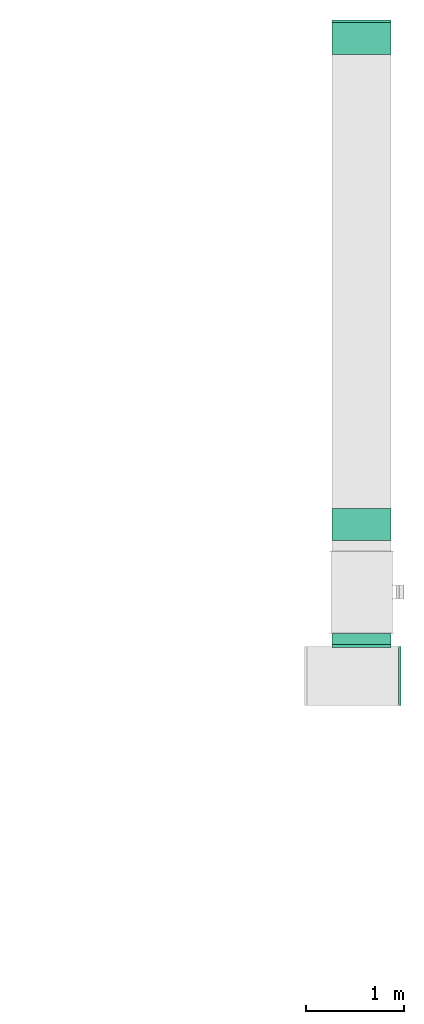
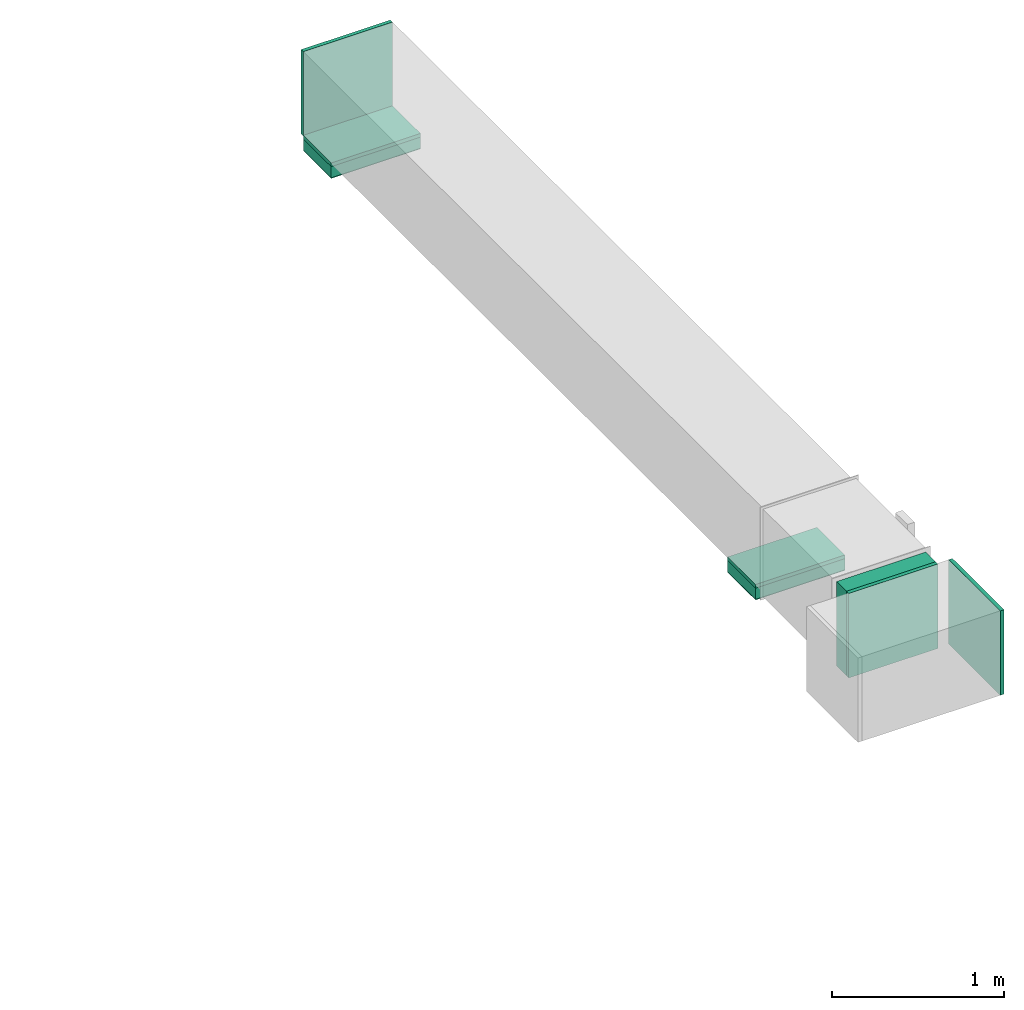
# One storey, part 5 of 9: 5 flow fittings, 3 flow segments, 2 flow terminals.
"""IFC2X3 building model written with IfcOpenShell, lengths in millimetres."""

from ifc_helpers import new_model, entity, si_unit, converted_unit, derived_unit, direction, frame, frame_2d, origin, origin_2d_with_axis, place, context, subcontext, project, spatial, rectangle, extrude, source, transform, mapped, material, type_object, type_shapes, element, save


model = new_model("IFC2X3")

# Units and contexts
model_context = context("Model", 3, precision=0.01, world=origin(), true_north=direction((6.12303176911189e-17, 1.0)))
body_context = subcontext(model_context, "Body", "Model", "MODEL_VIEW")
ifc_project = project(units=[si_unit("LENGTHUNIT", "METRE", prefix="MILLI"), si_unit("AREAUNIT", "SQUARE_METRE"), si_unit("VOLUMEUNIT", "CUBIC_METRE"), converted_unit("PLANEANGLEUNIT", "DEGREE", entity("IfcRatioMeasure", 0.0174532925199433), si_unit("PLANEANGLEUNIT", "RADIAN"), dimensions=[0, 0, 0, 0, 0, 0, 0]), si_unit("MASSUNIT", "GRAM", prefix="KILO"), derived_unit("MASSDENSITYUNIT", [(si_unit("MASSUNIT", "GRAM", prefix="KILO"), 1), (si_unit("LENGTHUNIT", "METRE"), -3)]), derived_unit("MOMENTOFINERTIAUNIT", [(si_unit("LENGTHUNIT", "METRE"), 4)]), si_unit("TIMEUNIT", "SECOND"), si_unit("FREQUENCYUNIT", "HERTZ"), si_unit("THERMODYNAMICTEMPERATUREUNIT", "DEGREE_CELSIUS"), derived_unit("THERMALTRANSMITTANCEUNIT", [(si_unit("MASSUNIT", "GRAM", prefix="KILO"), 1), (si_unit("THERMODYNAMICTEMPERATUREUNIT", "KELVIN"), -1), (si_unit("TIMEUNIT", "SECOND"), -3)]), derived_unit("VOLUMETRICFLOWRATEUNIT", [(si_unit("LENGTHUNIT", "METRE"), 3), (si_unit("TIMEUNIT", "SECOND"), -1)]), derived_unit("MASSFLOWRATEUNIT", [(si_unit("MASSUNIT", "GRAM", prefix="KILO"), 1), (si_unit("TIMEUNIT", "SECOND"), -1)]), derived_unit("ROTATIONALFREQUENCYUNIT", [(si_unit("TIMEUNIT", "SECOND"), -1)]), si_unit("ELECTRICCURRENTUNIT", "AMPERE"), si_unit("ELECTRICVOLTAGEUNIT", "VOLT"), si_unit("POWERUNIT", "WATT"), si_unit("FORCEUNIT", "NEWTON", prefix="KILO"), si_unit("ILLUMINANCEUNIT", "LUX"), si_unit("LUMINOUSFLUXUNIT", "LUMEN"), si_unit("LUMINOUSINTENSITYUNIT", "CANDELA"), derived_unit("USERDEFINED", [(si_unit("MASSUNIT", "GRAM", prefix="KILO"), -1), (si_unit("LENGTHUNIT", "METRE"), -2), (si_unit("TIMEUNIT", "SECOND"), 3), (si_unit("LUMINOUSFLUXUNIT", "LUMEN"), 1)]), derived_unit("LINEARVELOCITYUNIT", [(si_unit("LENGTHUNIT", "METRE"), 1), (si_unit("TIMEUNIT", "SECOND"), -1)]), si_unit("PRESSUREUNIT", "PASCAL"), derived_unit("USERDEFINED", [(si_unit("LENGTHUNIT", "METRE"), -2), (si_unit("MASSUNIT", "GRAM", prefix="KILO"), 1), (si_unit("TIMEUNIT", "SECOND"), -2)]), derived_unit("LINEARFORCEUNIT", [(si_unit("MASSUNIT", "GRAM", prefix="KILO"), 1), (si_unit("LENGTHUNIT", "METRE"), 1), (si_unit("TIMEUNIT", "SECOND"), -2), (si_unit("LENGTHUNIT", "METRE"), -1)]), derived_unit("PLANARFORCEUNIT", [(si_unit("MASSUNIT", "GRAM", prefix="KILO"), 1), (si_unit("LENGTHUNIT", "METRE"), 1), (si_unit("TIMEUNIT", "SECOND"), -2), (si_unit("LENGTHUNIT", "METRE"), -2)])], contexts=[model_context])

# Site, building, storey
site_placement = place(None, frame((0.0, -0.00077364408347762, 0.0)))
site = spatial("IfcSite", under=ifc_project, at=site_placement, CompositionType="ELEMENT")
building_placement = place(site_placement, origin())
building = spatial("IfcBuilding", under=site, at=building_placement, CompositionType="ELEMENT")
storey_placement = place(building_placement, frame((0.0, 0.0, 24000.0)))
storey = spatial("IfcBuildingStorey", under=building, at=storey_placement, CompositionType="ELEMENT", Elevation=24000.0)

# Flow segments
duct_segment_type = type_object("IfcDuctSegmentType", PredefinedType="NOTDEFINED")
flow_segment_1_placement = place(storey_placement, frame((63544.8764160069, 12186.6830168672, 2400.0)))
element("IfcFlowSegment", 1, at=flow_segment_1_placement, inside=storey, type_object=duct_segment_type, context=body_context, shape_type="SweptSolid", body=[
    extrude(rectangle(XDim=600.000000000002, YDim=325.0, at=origin_2d_with_axis()), frame((300.0, 162.5, 0.0), z_axis=(0.0, 0.0, 1.0), x_axis=(-1.0, 0.0, 0.0)), (0.0, 0.0, 1.0), 79.5999999999992),
])
flow_segment_2_placement = place(storey_placement, frame((63544.8764160069, 17126.3329274166, 2400.0)))
element("IfcFlowSegment", 2, at=flow_segment_2_placement, inside=storey, type_object=duct_segment_type, context=body_context, shape_type="SweptSolid", body=[
    extrude(rectangle(XDim=600.000000000002, YDim=325.0, at=frame_2d((0.0, 2.17426077142591e-12), x_axis=(1.0, 0.0))), frame((300.0, 162.500000000006, 0.0), z_axis=(0.0, 0.0, 1.0), x_axis=(-1.0, 0.0, 0.0)), (0.0, 0.0, 1.0), 79.6000000002634),
])
flow_segment_3_placement = place(storey_placement, frame((63544.8764160069, 11128.5000111377, 2499.6)))
element("IfcFlowSegment", 3, at=flow_segment_3_placement, inside=storey, type_object=duct_segment_type, context=body_context, shape_type="SweptSolid", body=[
    extrude(rectangle(XDim=114.291507549948, YDim=600.000000000002, at=origin_2d_with_axis()), frame((300.0, 57.1457537749738, 0.0), z_axis=(0.0, 0.0, 1.0), x_axis=(0.0, 1.0, 0.0)), (0.0, 0.0, 1.0), 600.000000000002),
])

# Flow fittings
ifc_material_1 = material()
duct_fitting_type_1 = type_object("IfcDuctFittingType", PredefinedType="NOTDEFINED", material=ifc_material_1)
shared_shape_1 = source(origin(), body_context, "Body", "SweptSolid", [
    extrude(rectangle(XDim=600.0, YDim=26.0960000000043, at=origin_2d_with_axis()), frame((6.95199999999999, 0.0, -300.0), z_axis=(0.0, 0.0, 1.0), x_axis=(0.0, -1.0, 0.0)), (0.0, 0.0, 1.0), 600.0),
])
type_shapes(duct_fitting_type_1, [shared_shape_1])
flow_fitting_1_placement = place(storey_placement, frame((63844.8764160069, 11108.5000111376, 2799.6), z_axis=(0.0, 0.0, -1.0), x_axis=(0.0, 1.0, 0.0)))
element("IfcFlowFitting", 4, at=flow_fitting_1_placement, inside=storey, type_object=duct_fitting_type_1, material=ifc_material_1, context=body_context, shape_type="MappedRepresentation", body=[
    mapped(shared_shape_1, transform((0.0, 0.0, 0.0), scale=1.0)),
])
duct_fitting_type_2 = type_object("IfcDuctFittingType", PredefinedType="NOTDEFINED", material=ifc_material_1)
shared_shape_2 = source(origin(), body_context, "Body", "SweptSolid", [
    extrude(rectangle(XDim=26.0960000000009, YDim=600.0, at=frame_2d((-4.66293670342566e-13, -1.4210854715202e-13), x_axis=(1.0, 0.0))), frame((6.95199999999999, 0.0, -162.5)), (0.0, 0.0, 1.0), 325.0),
])
type_shapes(duct_fitting_type_2, [shared_shape_2])
flow_fitting_2_placement = place(storey_placement, frame((63844.8764160069, 12349.1830168672, 2499.6), z_axis=(0.0, 1.0, 0.0), x_axis=(0.0, 0.0, -1.0)))
element("IfcFlowFitting", 5, at=flow_fitting_2_placement, inside=storey, type_object=duct_fitting_type_2, material=ifc_material_1, context=body_context, shape_type="MappedRepresentation", body=[
    mapped(shared_shape_2, transform((0.0, 0.0, 0.0), scale=1.0)),
])
duct_fitting_type_3 = type_object("IfcDuctFittingType", PredefinedType="NOTDEFINED", material=ifc_material_1)
shared_shape_3 = source(origin(), body_context, "Body", "SweptSolid", [
    extrude(rectangle(XDim=24.9999999999999, YDim=600.0, at=frame_2d((-2.46913600676635e-13, 0.0), x_axis=(1.0, 0.0))), frame((12.500000000006, 0.0, -300.0)), (0.0, 0.0, 1.0), 600.0),
])
type_shapes(duct_fitting_type_3, [shared_shape_3])
flow_fitting_3_placement = place(storey_placement, frame((63844.8764160069, 17451.3329274166, 2799.6), z_axis=(0.0, 0.0, 1.0), x_axis=(0.0, 1.0, 0.0)))
element("IfcFlowFitting", 6, at=flow_fitting_3_placement, inside=storey, type_object=duct_fitting_type_3, material=ifc_material_1, context=body_context, shape_type="MappedRepresentation", body=[
    mapped(shared_shape_3, transform((0.0, 0.0, 0.0), scale=1.0)),
])
flow_fitting_4_placement = place(storey_placement, frame((64220.8265415425, 10808.5000111377, 2799.6)))
element("IfcFlowFitting", 7, at=flow_fitting_4_placement, inside=storey, type_object=duct_fitting_type_3, material=ifc_material_1, context=body_context, shape_type="MappedRepresentation", body=[
    mapped(shared_shape_3, transform((0.0, 0.0, 0.0), scale=1.0)),
])
duct_fitting_type_4 = type_object("IfcDuctFittingType", PredefinedType="NOTDEFINED", material=ifc_material_1)
shared_shape_4 = source(origin(), body_context, "Body", "SweptSolid", [
    extrude(rectangle(XDim=600.0, YDim=26.096, at=origin_2d_with_axis()), frame((6.95199999999999, 0.0, -162.5), z_axis=(0.0, 0.0, 1.0), x_axis=(0.0, -1.0, 0.0)), (0.0, 0.0, 1.0), 325.0),
])
type_shapes(duct_fitting_type_4, [shared_shape_4])
flow_fitting_5_placement = place(storey_placement, frame((63844.8764160069, 17288.8329274166, 2499.6), z_axis=(0.0, -1.0, 0.0), x_axis=(0.0, 0.0, -1.0)))
element("IfcFlowFitting", 8, at=flow_fitting_5_placement, inside=storey, type_object=duct_fitting_type_4, material=ifc_material_1, context=body_context, shape_type="MappedRepresentation", body=[
    mapped(shared_shape_4, transform((0.0, 0.0, 0.0), scale=1.0)),
])

# Flow terminals
ifc_material_2 = material()
air_terminal_type = type_object("IfcAirTerminalType", PredefinedType="NOTDEFINED", material=ifc_material_2)
shared_shape_5 = source(origin(), body_context, "Body", "SweptSolid", [
    extrude(rectangle(XDim=4.0, YDim=599.999999999999, at=origin_2d_with_axis()), frame((0.0, -2.0, -162.500000000002), z_axis=(0.0, 0.0, 1.0), x_axis=(0.0, 1.0, 0.0)), (0.0, 0.0, 1.0), 325.000000000005),
])
type_shapes(air_terminal_type, [shared_shape_5])
for number, where, z_axis, x_axis in (
    (9, (63844.8764160069, 17288.8329274166, 2400.0), (0.0, -1.0, 0.0), (1.0, 0.0, 0.0)),
    (10, (63844.8764160069, 12349.1830168672, 2400.0), (0.0, -1.0, 0.0), (1.0, 0.0, 0.0)),
):
    element("IfcFlowTerminal", number, at=place(storey_placement, frame(where, z_axis=z_axis, x_axis=x_axis)), inside=storey, type_object=air_terminal_type, material=ifc_material_2, context=body_context, shape_type="MappedRepresentation", body=[
        mapped(shared_shape_5, transform((0.0, 0.0, 0.0), scale=1.0)),
    ])

save(model, "model.ifc")
